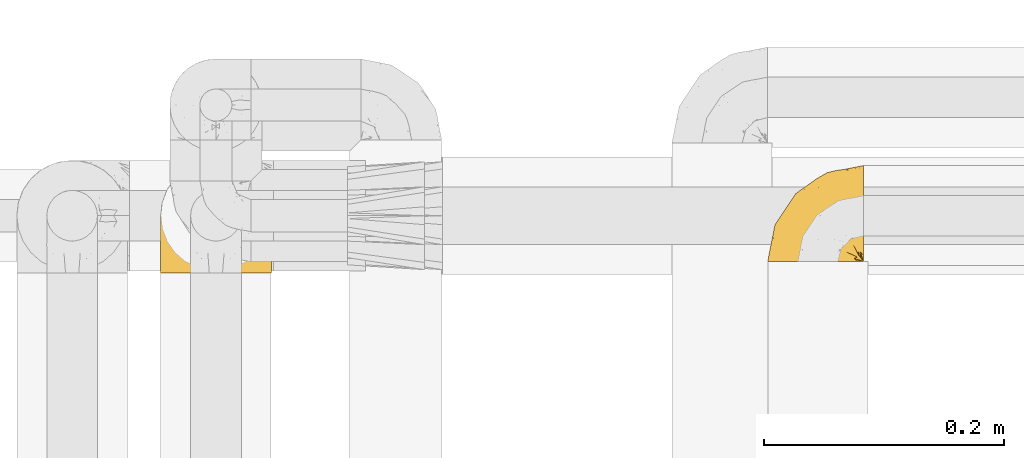
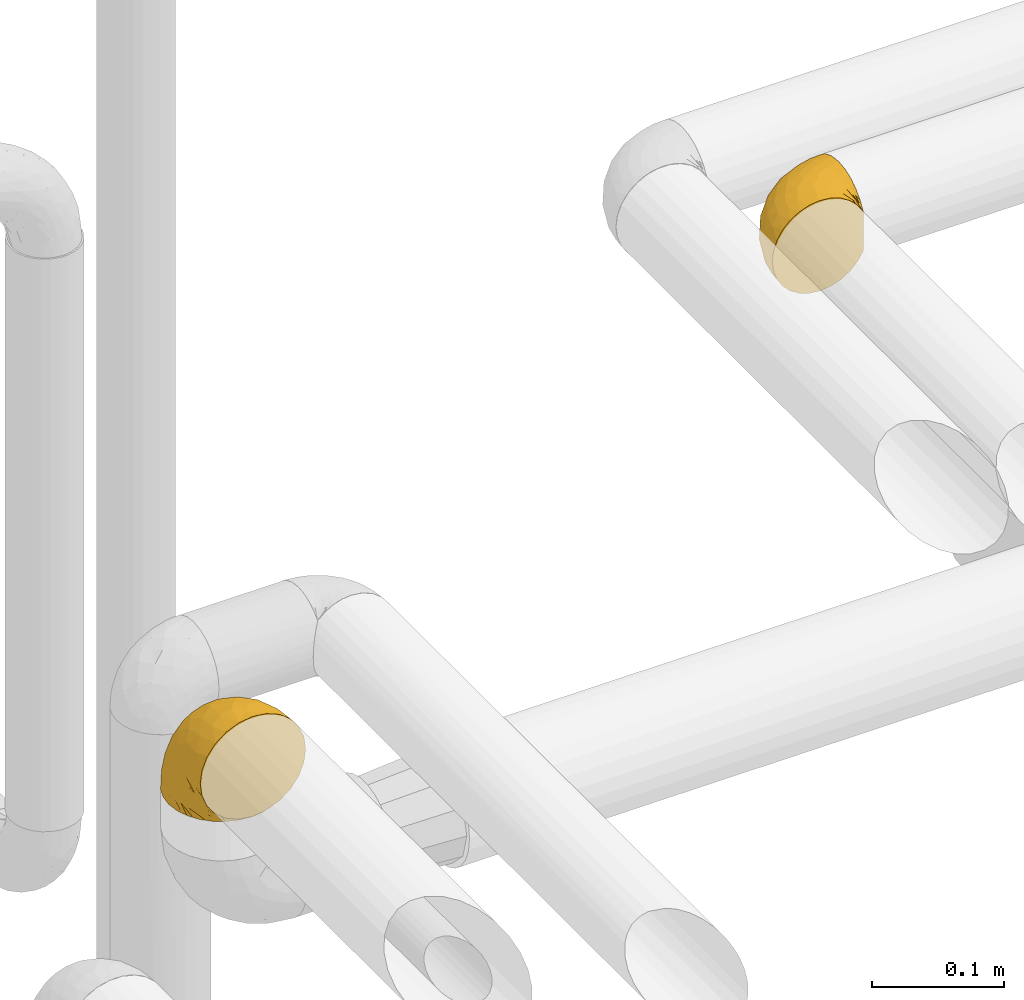
# One storey, part 429 of 827: 2 coverings.
"""IFC2X3 building model written with IfcOpenShell, lengths in millimetres."""

from ifc_helpers import new_model, entity, si_unit, converted_unit, derived_unit, direction, frame, origin, place, context, subcontext, project, spatial, faceted_brep, element, save


model = new_model("IFC2X3")

# Units and contexts
model_context = context("Model", 3, precision=0.01, world=origin(), true_north=direction((6.12303176911189e-17, 1.0)))
body_context = subcontext(model_context, "Body", "Model", "MODEL_VIEW")
ifc_project = project(units=[si_unit("LENGTHUNIT", "METRE", prefix="MILLI"), si_unit("AREAUNIT", "SQUARE_METRE"), si_unit("VOLUMEUNIT", "CUBIC_METRE"), converted_unit("PLANEANGLEUNIT", "DEGREE", entity("IfcRatioMeasure", 0.0174532925199433), si_unit("PLANEANGLEUNIT", "RADIAN"), dimensions=[0, 0, 0, 0, 0, 0, 0]), si_unit("MASSUNIT", "GRAM", prefix="KILO"), derived_unit("MASSDENSITYUNIT", [(si_unit("MASSUNIT", "GRAM", prefix="KILO"), 1), (si_unit("LENGTHUNIT", "METRE"), -3)]), derived_unit("MOMENTOFINERTIAUNIT", [(si_unit("LENGTHUNIT", "METRE"), 4)]), si_unit("TIMEUNIT", "SECOND"), si_unit("FREQUENCYUNIT", "HERTZ"), si_unit("THERMODYNAMICTEMPERATUREUNIT", "DEGREE_CELSIUS"), derived_unit("THERMALTRANSMITTANCEUNIT", [(si_unit("MASSUNIT", "GRAM", prefix="KILO"), 1), (si_unit("THERMODYNAMICTEMPERATUREUNIT", "KELVIN"), -1), (si_unit("TIMEUNIT", "SECOND"), -3)]), derived_unit("VOLUMETRICFLOWRATEUNIT", [(si_unit("LENGTHUNIT", "METRE"), 3), (si_unit("TIMEUNIT", "SECOND"), -1)]), derived_unit("MASSFLOWRATEUNIT", [(si_unit("MASSUNIT", "GRAM", prefix="KILO"), 1), (si_unit("TIMEUNIT", "SECOND"), -1)]), derived_unit("ROTATIONALFREQUENCYUNIT", [(si_unit("TIMEUNIT", "SECOND"), -1)]), si_unit("ELECTRICCURRENTUNIT", "AMPERE"), si_unit("ELECTRICVOLTAGEUNIT", "VOLT"), si_unit("POWERUNIT", "WATT"), si_unit("FORCEUNIT", "NEWTON", prefix="KILO"), si_unit("ILLUMINANCEUNIT", "LUX"), si_unit("LUMINOUSFLUXUNIT", "LUMEN"), si_unit("LUMINOUSINTENSITYUNIT", "CANDELA"), derived_unit("USERDEFINED", [(si_unit("MASSUNIT", "GRAM", prefix="KILO"), -1), (si_unit("LENGTHUNIT", "METRE"), -2), (si_unit("TIMEUNIT", "SECOND"), 3), (si_unit("LUMINOUSFLUXUNIT", "LUMEN"), 1)]), derived_unit("LINEARVELOCITYUNIT", [(si_unit("LENGTHUNIT", "METRE"), 1), (si_unit("TIMEUNIT", "SECOND"), -1)]), si_unit("PRESSUREUNIT", "PASCAL"), derived_unit("USERDEFINED", [(si_unit("LENGTHUNIT", "METRE"), -2), (si_unit("MASSUNIT", "GRAM", prefix="KILO"), 1), (si_unit("TIMEUNIT", "SECOND"), -2)]), derived_unit("LINEARFORCEUNIT", [(si_unit("MASSUNIT", "GRAM", prefix="KILO"), 1), (si_unit("LENGTHUNIT", "METRE"), 1), (si_unit("TIMEUNIT", "SECOND"), -2), (si_unit("LENGTHUNIT", "METRE"), -1)]), derived_unit("PLANARFORCEUNIT", [(si_unit("MASSUNIT", "GRAM", prefix="KILO"), 1), (si_unit("LENGTHUNIT", "METRE"), 1), (si_unit("TIMEUNIT", "SECOND"), -2), (si_unit("LENGTHUNIT", "METRE"), -2)])], contexts=[model_context])

# Site, building, storey
site_placement = place(None, origin())
site = spatial("IfcSite", under=ifc_project, at=site_placement, CompositionType="ELEMENT")
building_placement = place(site_placement, origin())
building = spatial("IfcBuilding", under=site, at=building_placement, CompositionType="ELEMENT")
storey_placement = place(building_placement, frame((0.0, 0.0, 28200.0)))
storey = spatial("IfcBuildingStorey", under=building, at=storey_placement, Name="08", CompositionType="ELEMENT", Elevation=28200.0)

# Coverings
covering_1_placement = place(storey_placement, frame((54648.74, 17460.4, 2956.55)))
element("IfcCovering", 1, at=covering_1_placement, inside=storey, Name=":ADSK_", ObjectType=":ADSK_", PredefinedType="INSULATION", context=body_context, shape_type="Brep", body=[
    faceted_brep([(25.28, 1.6, 81.15), (17.35, 1.6, 76.16), (10.72, 1.6, 69.53), (5.74, 1.6, 61.6), (2.64, 1.6, 52.75), (1.6, 1.6, 43.45), (2.65, 1.6, 34.13), (5.74, 1.6, 25.28), (10.73, 1.6, 17.35), (17.36, 1.6, 10.72), (25.29, 1.6, 5.74), (34.14, 1.6, 2.64), (43.45, 1.6, 1.6), (52.82, 1.6, 2.66), (61.71, 1.6, 5.79), (69.67, 1.6, 10.83), (76.31, 1.6, 17.53), (81.27, 1.6, 25.53), (81.27, 1.6, 26.45), (81.27, 1.6, 27.37), (81.27, 1.6, 28.17), (81.27, 1.6, 29.49), (81.27, 1.6, 30.81), (81.27, 1.6, 32.13), (81.27, 1.6, 33.45), (81.27, 1.6, 34.78), (81.27, 1.6, 36.1), (81.27, 1.6, 37.42), (81.27, 1.6, 38.74), (81.27, 1.6, 40.06), (81.27, 1.6, 41.38), (81.27, 1.6, 42.7), (81.27, 1.6, 44.02), (81.27, 1.6, 45.34), (81.27, 1.6, 46.66), (81.27, 1.6, 47.58), (81.27, 1.6, 48.5), (81.27, 1.6, 49.41), (81.27, 1.6, 50.33), (81.27, 1.6, 51.25), (81.27, 1.6, 52.17), (81.27, 1.6, 53.09), (81.27, 1.6, 54.01), (81.27, 1.6, 54.93), (81.27, 1.6, 55.85), (81.27, 1.6, 56.76), (81.27, 1.6, 57.68), (81.27, 1.6, 58.6), (81.27, 1.6, 59.52), (81.27, 1.6, 60.44), (81.27, 1.6, 61.36), (76.3, 1.6, 69.37), (69.66, 1.6, 76.07), (61.69, 1.6, 81.11), (52.8, 1.6, 84.24), (43.45, 1.6, 85.3), (34.13, 1.6, 84.24), (81.45, 6.74, 17.52), (81.45, 13.37, 10.83), (81.45, 21.34, 5.79), (81.45, 30.23, 2.66), (81.45, 39.6, 1.6), (81.45, 50.43, 3.02), (81.45, 60.52, 7.2), (81.45, 69.19, 13.85), (81.45, 75.84, 22.52), (81.45, 80.02, 32.61), (81.45, 81.45, 43.45), (81.45, 80.02, 54.28), (81.45, 75.84, 64.37), (81.45, 69.19, 73.04), (81.45, 60.52, 79.69), (81.45, 50.43, 83.87), (81.45, 39.6, 85.3), (81.45, 30.23, 84.23), (81.45, 21.34, 81.1), (81.45, 13.37, 76.06), (81.45, 6.74, 69.37), (81.45, 1.77, 61.36), (81.45, 1.77, 60.44), (81.45, 1.77, 59.12), (81.45, 1.77, 58.0), (81.45, 1.77, 56.88), (81.45, 1.77, 55.76), (81.45, 1.77, 54.64), (81.45, 1.77, 53.52), (81.45, 1.77, 52.4), (81.45, 1.77, 51.28), (81.45, 1.77, 50.16), (81.45, 1.77, 49.04), (81.45, 1.77, 47.92), (81.45, 1.77, 46.8), (81.45, 1.77, 45.68), (81.45, 1.77, 44.56), (81.45, 1.77, 43.45), (81.45, 1.77, 42.12), (81.45, 1.77, 40.8), (81.45, 1.77, 39.48), (81.45, 1.77, 38.16), (81.45, 1.77, 36.84), (81.45, 1.77, 35.52), (81.45, 1.77, 34.2), (81.45, 1.77, 32.88), (81.45, 1.77, 31.96), (81.45, 1.77, 31.05), (81.45, 1.77, 30.13), (81.45, 1.77, 29.21), (81.45, 1.77, 28.29), (81.45, 1.77, 27.37), (81.45, 1.77, 26.45), (81.45, 1.77, 25.53), (81.33, 1.73, 54.08), (81.32, 1.72, 55.16), (81.33, 1.73, 36.18), (81.32, 1.72, 35.13), (81.33, 1.73, 44.01), (81.32, 1.73, 45.08), (81.32, 1.72, 61.36), (81.32, 1.72, 59.98), (81.32, 1.72, 46.18), (81.32, 1.72, 26.74), (81.32, 1.72, 47.36), (81.32, 1.73, 29.67), (81.34, 1.74, 28.72), (81.32, 1.72, 39.77), (81.31, 1.71, 52.96), (81.33, 1.73, 51.84), (81.31, 1.71, 40.8), (81.32, 1.72, 41.87), (81.33, 1.73, 42.94), (81.32, 1.72, 27.77), (81.33, 1.73, 48.4), (81.32, 1.72, 37.21), (81.33, 1.73, 33.54), (81.32, 1.72, 32.49), (81.32, 1.72, 30.69), (81.32, 1.72, 50.69), (81.31, 1.71, 49.6), (81.32, 1.72, 56.32), (81.33, 1.73, 57.44), (81.31, 1.71, 58.88), (81.32, 1.72, 25.53), (81.3, 1.68, 61.36), (81.29, 1.64, 61.36), (81.29, 1.64, 25.53), (81.3, 1.68, 25.53), (81.4, 1.75, 61.36), (81.36, 1.74, 61.36), (81.36, 1.74, 25.53), (81.4, 1.75, 25.53), (81.3, 1.7, 31.59), (81.33, 1.73, 38.71), (74.06, 24.54, 3.97), (45.99, 11.1, 1.6), (58.35, 8.47, 3.97), (67.76, 9.11, 8.09), (66.18, 4.86, 8.09), (76.46, 5.0, 16.43), (77.33, 6.81, 15.73), (71.95, 37.05, 1.6), (72.25, 9.03, 10.79), (78.91, 9.47, 13.99), (76.42, 16.39, 8.08), (73.52, 3.95, 14.0), (76.9, 9.9, 12.83), (65.25, 22.7, 3.18), (62.45, 34.5, 1.6), (74.31, 37.68, 1.6), (59.38, 15.82, 3.28), (48.54, 20.6, 1.6), (67.72, 14.37, 6.28), (55.49, 27.55, 1.6), (79.73, 5.2, 19.06), (73.23, 14.88, 8.08), (45.36, 8.73, 1.6), (15.81, 44.27, 32.11), (6.4, 20.94, 29.62), (7.67, 32.15, 43.45), (68.46, 46.13, 2.45), (59.33, 42.67, 2.5), (48.7, 55.18, 9.73), (53.94, 67.27, 17.97), (65.02, 62.91, 10.24), (60.77, 51.5, 4.78), (72.07, 54.79, 4.78), (26.25, 25.78, 8.01), (22.29, 13.05, 8.01), (16.0, 18.46, 13.85), (46.93, 32.4, 2.42), (14.19, 31.07, 21.17), (58.46, 77.32, 35.73), (61.51, 75.62, 27.43), (4.64, 16.9, 43.45), (68.93, 71.69, 17.97), (29.62, 61.4, 35.71), (24.85, 54.47, 29.47), (38.55, 27.66, 3.41), (31.27, 14.53, 3.94), (9.35, 15.56, 21.17), (37.15, 42.26, 7.92), (47.07, 41.51, 4.25), (26.49, 36.93, 11.75), (23.01, 42.72, 18.31), (19.4, 44.68, 24.94), (48.06, 71.2, 28.78), (42.46, 70.48, 35.82), (50.89, 75.37, 43.45), (35.78, 63.65, 28.38), (24.98, 58.06, 43.45), (16.33, 45.11, 43.45), (66.14, 78.4, 43.45), (30.96, 54.95, 21.21), (41.83, 59.31, 16.48), (33.28, 49.01, 13.85), (37.94, 66.71, 43.45), (67.39, 53.75, 82.11), (58.47, 77.27, 51.41), (32.5, 61.6, 57.45), (15.79, 44.24, 54.78), (15.99, 18.46, 73.03), (9.34, 15.55, 65.7), (56.91, 60.14, 76.65), (63.5, 70.5, 68.92), (44.08, 63.0, 68.01), (26.24, 25.78, 78.88), (22.27, 13.05, 78.88), (31.26, 14.53, 82.94), (23.95, 48.5, 64.44), (63.79, 44.23, 84.49), (62.45, 34.5, 85.3), (71.95, 37.05, 85.3), (45.36, 8.73, 85.3), (67.83, 77.68, 57.84), (70.28, 64.08, 76.65), (42.11, 70.25, 51.19), (6.39, 20.93, 57.26), (43.54, 49.9, 78.14), (58.03, 49.6, 82.35), (14.18, 31.06, 65.7), (56.34, 39.62, 84.61), (48.09, 34.42, 84.36), (48.54, 20.6, 85.3), (55.49, 27.55, 85.3), (21.78, 33.36, 73.03), (38.54, 27.68, 83.48), (45.99, 11.1, 85.3), (72.79, 46.67, 84.54), (33.26, 49.0, 73.03), (35.53, 38.94, 79.54), (53.66, 73.05, 59.46), (43.03, 56.63, 73.5), (49.68, 43.85, 82.57), (74.06, 24.54, 82.92), (59.37, 15.82, 83.62), (58.34, 8.47, 82.92), (67.75, 9.12, 78.81), (78.91, 9.47, 72.9), (76.9, 9.91, 74.06), (78.08, 16.85, 78.81), (73.23, 14.88, 78.81), (79.73, 5.2, 67.83), (77.34, 6.81, 71.15), (73.51, 3.96, 72.91), (76.45, 5.0, 70.47), (66.41, 5.86, 78.81), (67.7, 14.38, 80.62), (72.24, 9.04, 76.11), (65.25, 22.7, 83.71)], [[[0, 1, 2, 3, 4, 5, 6, 7, 8, 9, 10, 11, 12, 13, 14, 15, 16, 17, 18, 19, 20, 21, 22, 23, 24, 25, 26, 27, 28, 29, 30, 31, 32, 33, 34, 35, 36, 37, 38, 39, 40, 41, 42, 43, 44, 45, 46, 47, 48, 49, 50, 51, 52, 53, 54, 55, 56]], [[57, 58, 59, 60, 61, 62, 63, 64, 65, 66, 67, 68, 69, 70, 71, 72, 73, 74, 75, 76, 77, 78, 79, 80, 81, 82, 83, 84, 85, 86, 87, 88, 89, 90, 91, 92, 93, 94, 95, 96, 97, 98, 99, 100, 101, 102, 103, 104, 105, 106, 107, 108, 109, 110]], [[111, 84, 112]], [[113, 26, 114]], [[114, 101, 100]], [[115, 93, 116]], [[79, 117, 118]], [[33, 116, 119]], [[117, 49, 118]], [[19, 18, 120]], [[119, 121, 34]], [[122, 21, 123]], [[97, 96, 124]], [[86, 125, 126]], [[116, 92, 119]], [[127, 96, 128]], [[32, 129, 115]], [[19, 120, 130]], [[121, 90, 131]], [[94, 115, 129]], [[115, 116, 32]], [[118, 49, 48]], [[113, 99, 132]], [[133, 114, 25]], [[24, 134, 133]], [[135, 22, 122]], [[136, 137, 88]], [[84, 83, 112]], [[138, 82, 139]], [[130, 20, 19]], [[118, 48, 140]], [[81, 140, 139]], [[123, 21, 20]], [[141, 120, 18]], [[139, 82, 81]], [[130, 107, 123]], [[49, 117, 142, 143, 50]], [[18, 17, 144, 145, 141]], [[79, 78, 146, 147, 117]], [[109, 141, 148, 149, 110]], [[102, 133, 134]], [[105, 135, 122]], [[118, 80, 79]], [[80, 118, 140]], [[120, 109, 108]], [[47, 46, 140, 48]], [[81, 80, 140]], [[44, 112, 138]], [[93, 115, 94]], [[46, 139, 140]], [[46, 45, 139]], [[139, 45, 138]], [[138, 112, 83]], [[85, 84, 111]], [[112, 43, 111]], [[83, 82, 138]], [[106, 122, 123]], [[105, 122, 106]], [[21, 122, 22]], [[124, 29, 28]], [[33, 32, 116]], [[128, 129, 31]], [[32, 31, 129]], [[34, 33, 119]], [[116, 93, 92]], [[129, 95, 94]], [[95, 129, 128]], [[41, 40, 125, 42]], [[119, 91, 121]], [[36, 35, 131, 37]], [[137, 131, 89]], [[121, 131, 35]], [[90, 121, 91]], [[119, 92, 91]], [[136, 126, 39]], [[125, 86, 85]], [[42, 125, 111]], [[85, 111, 125]], [[150, 23, 22]], [[130, 108, 107]], [[130, 123, 20]], [[107, 106, 123]], [[137, 37, 131]], [[136, 38, 137]], [[89, 88, 137]], [[131, 90, 89]], [[124, 151, 97]], [[40, 39, 126]], [[87, 126, 136]], [[86, 126, 87]], [[136, 88, 87]], [[40, 126, 125]], [[39, 38, 136]], [[95, 128, 96]], [[30, 128, 31]], [[29, 124, 127]], [[127, 128, 30]], [[151, 124, 28]], [[127, 30, 29]], [[127, 124, 96]], [[151, 98, 97]], [[45, 44, 138]], [[26, 113, 132]], [[113, 100, 99]], [[132, 151, 27]], [[27, 26, 132]], [[26, 25, 114]], [[100, 113, 114]], [[101, 133, 102]], [[133, 101, 114]], [[28, 27, 151]], [[132, 99, 98]], [[23, 134, 24]], [[25, 24, 133]], [[134, 23, 150]], [[135, 104, 150]], [[150, 104, 103]], [[103, 102, 134]], [[130, 120, 108]], [[109, 120, 141]], [[42, 111, 43]], [[112, 44, 43]], [[104, 135, 105]], [[134, 150, 103]], [[135, 150, 22]], [[35, 34, 121]], [[137, 38, 37]], [[98, 151, 132]], [[59, 152, 60]], [[13, 153, 154]], [[155, 156, 154]], [[157, 158, 141]], [[159, 60, 152]], [[160, 157, 155]], [[161, 162, 58]], [[58, 162, 59]], [[144, 16, 163]], [[58, 57, 161]], [[162, 161, 164]], [[157, 163, 155]], [[163, 16, 15]], [[57, 149, 161]], [[152, 165, 166]], [[157, 144, 163]], [[60, 159, 167, 61]], [[156, 14, 154]], [[163, 156, 155]], [[155, 154, 168]], [[168, 154, 169]], [[155, 170, 160]], [[57, 110, 149]], [[144, 17, 16]], [[156, 15, 14]], [[171, 165, 168]], [[158, 164, 172]], [[14, 13, 154]], [[157, 141, 145, 144]], [[173, 164, 158]], [[173, 160, 170]], [[171, 166, 165]], [[168, 165, 170]], [[168, 169, 171]], [[152, 173, 165]], [[170, 155, 168]], [[165, 173, 170]], [[160, 173, 158]], [[172, 149, 148]], [[148, 141, 158]], [[158, 157, 160]], [[152, 166, 159]], [[173, 152, 162]], [[59, 162, 152]], [[13, 12, 174, 153]], [[153, 169, 154]], [[15, 156, 163]], [[162, 164, 173]], [[172, 164, 161]], [[149, 172, 161]], [[158, 172, 148]], [[175, 176, 177]], [[178, 166, 179]], [[180, 181, 182]], [[183, 184, 178]], [[185, 186, 187]], [[171, 188, 179]], [[174, 12, 11]], [[189, 176, 175]], [[190, 66, 191]], [[176, 6, 192]], [[193, 65, 64]], [[63, 184, 182]], [[63, 182, 64]], [[65, 193, 191]], [[184, 63, 62]], [[175, 194, 195]], [[196, 169, 197]], [[174, 11, 197]], [[8, 7, 198]], [[187, 9, 8]], [[197, 169, 153, 174]], [[197, 11, 10]], [[186, 197, 10]], [[199, 180, 200]], [[197, 185, 196]], [[201, 189, 202]], [[201, 187, 189]], [[195, 203, 175]], [[191, 204, 190]], [[176, 7, 6]], [[177, 176, 192]], [[189, 198, 176]], [[65, 191, 66]], [[198, 187, 8]], [[205, 206, 190]], [[9, 186, 10]], [[181, 207, 204]], [[208, 175, 177, 209]], [[66, 190, 210]], [[211, 212, 213]], [[190, 204, 205]], [[180, 182, 183]], [[193, 182, 181]], [[62, 61, 167]], [[196, 185, 199]], [[196, 200, 188]], [[6, 5, 192]], [[176, 198, 7]], [[187, 198, 189]], [[187, 186, 9]], [[197, 186, 185]], [[200, 180, 183]], [[180, 213, 212]], [[179, 183, 178]], [[185, 201, 199]], [[210, 190, 206]], [[210, 67, 66]], [[205, 204, 207]], [[194, 205, 207]], [[194, 214, 205]], [[195, 194, 207]], [[208, 194, 175]], [[207, 211, 195]], [[202, 203, 211]], [[212, 207, 181]], [[202, 211, 213]], [[201, 202, 213]], [[189, 175, 203]], [[199, 201, 213]], [[187, 201, 185]], [[180, 199, 213]], [[196, 199, 200]], [[211, 203, 195]], [[189, 203, 202]], [[207, 212, 211]], [[180, 212, 181]], [[214, 194, 208]], [[214, 206, 205]], [[196, 188, 169]], [[181, 204, 191]], [[182, 193, 64]], [[191, 193, 181]], [[178, 62, 167]], [[182, 184, 183]], [[62, 178, 184]], [[178, 167, 159, 166]], [[171, 179, 166]], [[200, 183, 179]], [[179, 188, 200]], [[169, 188, 171]], [[71, 215, 72]], [[206, 216, 210]], [[217, 208, 218]], [[216, 68, 210]], [[219, 220, 2]], [[221, 222, 223]], [[224, 225, 226]], [[227, 223, 217]], [[228, 229, 230]], [[56, 231, 226]], [[232, 222, 69]], [[56, 55, 231]], [[70, 233, 71]], [[71, 233, 215]], [[0, 56, 226]], [[208, 217, 234]], [[218, 177, 235]], [[221, 236, 237]], [[238, 220, 219]], [[1, 219, 2]], [[68, 216, 232]], [[235, 3, 220]], [[235, 192, 4]], [[1, 0, 225]], [[228, 239, 229]], [[240, 241, 242]], [[243, 238, 219]], [[224, 226, 244]], [[226, 241, 244]], [[3, 235, 4]], [[69, 222, 70]], [[225, 219, 1]], [[218, 235, 238]], [[243, 219, 224]], [[218, 227, 217]], [[3, 2, 220]], [[218, 208, 209, 177]], [[226, 231, 245, 241]], [[215, 228, 246]], [[247, 248, 236]], [[248, 224, 244]], [[223, 222, 249]], [[233, 222, 221]], [[242, 239, 240]], [[248, 247, 243]], [[217, 223, 249]], [[250, 247, 236]], [[216, 234, 249]], [[218, 238, 227]], [[192, 235, 177]], [[192, 5, 4]], [[72, 246, 73]], [[235, 220, 238]], [[226, 225, 0]], [[219, 225, 224]], [[240, 248, 244]], [[239, 242, 229]], [[236, 248, 251]], [[68, 67, 210]], [[234, 216, 206]], [[216, 249, 232]], [[234, 206, 214, 208]], [[249, 234, 217]], [[222, 232, 249]], [[69, 68, 232]], [[246, 228, 230]], [[237, 228, 215]], [[243, 227, 238]], [[223, 227, 247]], [[73, 246, 230]], [[215, 246, 72]], [[248, 243, 224]], [[227, 243, 247]], [[237, 236, 251]], [[250, 221, 223]], [[222, 233, 70]], [[215, 233, 221]], [[221, 237, 215]], [[239, 237, 251]], [[237, 239, 228]], [[239, 251, 240]], [[248, 240, 251]], [[241, 240, 244]], [[221, 250, 236]], [[223, 247, 250]], [[74, 230, 252]], [[253, 254, 255]], [[146, 77, 256]], [[257, 258, 259]], [[260, 256, 257]], [[260, 261, 147]], [[75, 74, 252]], [[51, 143, 262]], [[263, 143, 142, 117]], [[256, 77, 76]], [[252, 258, 75]], [[253, 241, 254]], [[254, 245, 54]], [[258, 256, 76]], [[53, 52, 264]], [[255, 265, 253]], [[254, 264, 255]], [[255, 264, 262]], [[75, 258, 76]], [[265, 255, 266]], [[255, 262, 263]], [[51, 50, 143]], [[54, 245, 231, 55]], [[51, 262, 52]], [[253, 267, 242]], [[254, 54, 53]], [[266, 259, 265]], [[146, 78, 77]], [[263, 117, 261]], [[146, 256, 260]], [[257, 259, 261]], [[267, 253, 265]], [[229, 267, 252]], [[242, 267, 229]], [[242, 241, 253]], [[252, 267, 259]], [[255, 263, 266]], [[259, 267, 265]], [[261, 117, 147]], [[263, 261, 266]], [[259, 266, 261]], [[230, 74, 73]], [[230, 229, 252]], [[259, 258, 252]], [[254, 241, 245]], [[53, 264, 254]], [[52, 262, 264]], [[143, 263, 262]], [[258, 257, 256]], [[261, 260, 257]], [[146, 260, 147]]]),
])
covering_2_placement = place(storey_placement, frame((54141.99, 17450.4, 2650.4)))
element("IfcCovering", 2, at=covering_2_placement, inside=storey, Name=":ADSK_", ObjectType=":ADSK_", PredefinedType="INSULATION", context=body_context, shape_type="Brep", body=[
    faceted_brep([(11.68, 78.41, 1.6), (19.0, 85.72, 1.6), (27.76, 91.22, 1.6), (37.52, 94.64, 1.6), (47.8, 95.8, 1.6), (58.08, 94.64, 1.6), (67.85, 91.22, 1.6), (76.61, 85.71, 1.6), (83.92, 78.39, 1.6), (89.42, 69.63, 1.6), (92.84, 59.87, 1.6), (94.0, 49.6, 1.6), (93.53, 45.45, 1.6), (93.18, 42.38, 1.6), (92.84, 39.31, 1.6), (91.13, 34.43, 1.6), (89.42, 29.54, 1.6), (86.66, 25.16, 1.6), (83.91, 20.78, 1.6), (80.25, 17.13, 1.6), (76.59, 13.47, 1.6), (67.83, 7.97, 1.6), (62.95, 6.26, 1.6), (58.07, 4.55, 1.6), (47.8, 3.4, 1.6), (37.51, 4.55, 1.6), (32.63, 6.26, 1.6), (27.74, 7.97, 1.6), (18.98, 13.48, 1.6), (15.33, 17.14, 1.6), (11.67, 20.8, 1.6), (8.92, 25.18, 1.6), (6.17, 29.56, 1.6), (4.46, 34.44, 1.6), (2.75, 39.32, 1.6), (2.41, 42.39, 1.6), (2.06, 45.45, 1.6), (1.6, 49.6, 1.6), (2.75, 59.88, 1.6), (6.17, 69.65, 1.6), (47.8, 1.6, 3.4), (59.75, 1.6, 4.97), (70.9, 1.6, 9.58), (75.68, 1.6, 13.26), (80.46, 1.6, 16.93), (84.13, 1.6, 21.71), (87.81, 1.6, 26.5), (90.11, 1.6, 32.07), (92.42, 1.6, 37.64), (92.9, 1.6, 41.25), (93.17, 1.6, 43.34), (93.45, 1.6, 45.42), (94.0, 1.6, 49.6), (92.42, 1.6, 61.55), (87.81, 1.6, 72.7), (80.46, 1.6, 82.26), (70.9, 1.6, 89.61), (59.75, 1.6, 94.22), (47.8, 1.6, 95.8), (35.84, 1.6, 94.22), (24.7, 1.6, 89.61), (15.13, 1.6, 82.26), (7.78, 1.6, 72.7), (3.17, 1.6, 61.55), (1.6, 1.6, 49.6), (2.14, 1.6, 45.42), (2.69, 1.6, 41.25), (3.17, 1.6, 37.64), (5.48, 1.6, 32.07), (7.78, 1.6, 26.5), (11.46, 1.6, 21.71), (15.13, 1.6, 16.93), (19.91, 1.6, 13.26), (24.7, 1.6, 9.58), (35.84, 1.6, 4.97), (23.61, 36.81, 81.55), (31.99, 23.28, 90.4), (35.87, 45.8, 83.0), (47.8, 30.7, 91.18), (40.43, 21.2, 93.13), (47.8, 12.96, 94.0), (31.83, 66.19, 66.19), (23.37, 54.51, 70.92), (21.41, 17.98, 85.95), (3.07, 36.69, 49.74), (1.6, 35.54, 35.54), (1.6, 31.64, 38.14), (1.6, 27.75, 40.74), (1.6, 23.86, 43.34), (1.6, 19.96, 45.94), (13.45, 22.8, 77.59), (15.25, 42.67, 71.17), (8.07, 33.21, 65.81), (16.0, 59.45, 59.03), (17.34, 71.5, 45.85), (10.58, 62.66, 45.79), (5.34, 54.5, 41.42), (2.39, 47.57, 34.51), (8.36, 48.81, 56.04), (10.04, 74.98, 15.15), (2.59, 18.7, 56.51), (6.28, 15.75, 68.39), (34.28, 91.17, 23.33), (38.73, 85.28, 42.86), (27.25, 82.58, 39.42), (29.88, 75.78, 53.58), (38.6, 74.98, 59.17), (23.44, 67.27, 59.06), (25.25, 87.38, 22.63), (17.23, 82.04, 20.55), (47.8, 94.0, 12.96), (47.8, 77.8, 56.96), (47.8, 67.38, 67.38), (2.53, 56.2, 18.72), (1.6, 48.85, 5.33), (1.6, 48.11, 9.07), (1.6, 47.57, 11.79), (1.6, 47.03, 14.51), (1.6, 46.48, 17.24), (1.6, 45.94, 19.96), (5.71, 65.78, 21.03), (1.6, 17.24, 46.48), (1.6, 14.51, 47.03), (1.6, 11.79, 47.57), (1.6, 9.07, 48.11), (1.6, 7.2, 48.48), (1.6, 5.33, 48.85), (47.8, 91.18, 30.7), (1.6, 43.34, 23.86), (1.6, 40.74, 27.75), (1.6, 38.14, 31.64), (11.89, 72.73, 31.26), (47.8, 56.96, 77.8), (39.69, 62.23, 72.75), (47.8, 84.49, 43.83), (47.8, 43.83, 84.49), (13.84, 12.05, 14.58), (9.16, 18.95, 16.17), (15.79, 13.02, 10.82), (25.75, 8.34, 4.64), (16.09, 14.63, 7.71), (7.51, 11.09, 25.13), (3.99, 13.66, 32.66), (2.66, 20.08, 34.94), (3.16, 9.61, 36.76), (2.35, 9.48, 40.48), (2.23, 16.1, 39.25), (38.35, 3.42, 3.69), (6.18, 26.63, 13.99), (2.7, 33.72, 21.85), (2.93, 34.77, 17.93), (16.01, 6.75, 15.11), (9.08, 13.31, 21.14), (9.3, 21.11, 12.7), (11.68, 19.94, 7.21), (4.65, 8.67, 32.27), (3.65, 26.11, 25.68), (3.61, 29.3, 22.18), (12.8, 6.32, 18.79), (2.43, 39.92, 10.12), (6.83, 27.05, 9.47), (21.65, 6.04, 10.45), (3.7, 34.4, 11.29), (47.8, 2.87, 2.87), (3.37, 20.92, 31.16), (7.03, 27.43, 6.31), (7.87, 7.54, 25.62), (7.26, 18.45, 21.18), (3.41, 23.88, 28.81), (23.81, 7.77, 7.45), (86.5, 13.3, 21.14), (88.08, 11.09, 25.13), (82.79, 6.33, 18.79), (94.0, 9.07, 48.11), (94.0, 5.33, 48.85), (94.0, 14.51, 47.03), (94.0, 11.79, 47.57), (57.24, 3.42, 3.69), (71.76, 7.76, 7.44), (94.0, 47.03, 14.51), (94.0, 47.57, 11.79), (94.0, 48.85, 5.33), (94.0, 48.11, 9.07), (79.49, 14.62, 7.71), (88.75, 27.03, 9.47), (92.93, 20.08, 34.94), (92.22, 20.92, 31.16), (94.0, 27.75, 40.74), (94.0, 31.64, 38.14), (92.43, 9.61, 36.76), (93.24, 9.48, 40.48), (69.82, 8.33, 4.63), (79.57, 6.74, 15.11), (81.74, 12.04, 14.58), (94.0, 23.86, 43.34), (94.0, 19.96, 45.94), (93.36, 16.1, 39.25), (83.9, 19.93, 7.21), (86.28, 21.1, 12.69), (93.16, 39.92, 10.14), (92.88, 33.68, 21.81), (91.98, 29.28, 22.19), (89.41, 26.62, 14.0), (91.93, 26.08, 25.69), (86.42, 18.93, 16.17), (88.82, 27.87, 6.66), (92.66, 34.75, 17.92), (73.93, 6.04, 10.45), (94.0, 38.14, 31.64), (79.5, 12.79, 10.64), (91.89, 34.41, 11.31), (94.0, 45.94, 19.96), (94.0, 43.34, 23.86), (94.0, 40.74, 27.75), (91.6, 13.66, 32.66), (94.0, 17.24, 46.48), (90.94, 8.67, 32.27), (94.0, 35.54, 35.54), (92.16, 23.83, 28.77), (88.32, 18.43, 21.17), (86.13, 6.03, 23.36), (94.0, 46.48, 17.24), (93.2, 34.52, 47.58), (55.16, 21.2, 93.13), (82.02, 23.82, 77.44), (84.29, 41.32, 66.78), (76.94, 47.62, 71.68), (68.33, 52.66, 74.96), (71.98, 36.81, 81.55), (92.52, 49.75, 36.7), (92.9, 19.07, 56.9), (59.72, 45.8, 83.0), (63.6, 23.28, 90.4), (88.89, 21.35, 67.83), (74.18, 17.98, 85.95), (68.35, 82.57, 39.41), (61.33, 91.17, 23.33), (56.86, 85.27, 42.87), (68.62, 73.89, 53.92), (63.76, 66.19, 66.19), (72.19, 62.43, 64.12), (88.69, 63.53, 33.13), (92.19, 58.45, 23.1), (89.75, 67.16, 16.98), (59.86, 76.72, 55.72), (55.9, 62.22, 72.75), (77.99, 81.54, 23.77), (85.21, 74.8, 18.41), (74.99, 75.83, 43.7), (90.23, 41.45, 54.53), (70.75, 88.2, 17.73), (81.72, 71.6, 38.98), (86.53, 56.23, 50.28), (79.6, 59.44, 59.02)], [[[0, 1, 2, 3, 4, 5, 6, 7, 8, 9, 10, 11, 12, 13, 14, 15, 16, 17, 18, 19, 20, 21, 22, 23, 24, 25, 26, 27, 28, 29, 30, 31, 32, 33, 34, 35, 36, 37, 38, 39]], [[40, 41, 42, 43, 44, 45, 46, 47, 48, 49, 50, 51, 52, 53, 54, 55, 56, 57, 58, 59, 60, 61, 62, 63, 64, 65, 66, 67, 68, 69, 70, 71, 72, 73, 74]], [[75, 76, 77]], [[78, 79, 80]], [[77, 81, 82]], [[76, 75, 83]], [[84, 85, 86, 87, 88, 89]], [[90, 91, 92]], [[76, 60, 59]], [[93, 94, 95]], [[90, 62, 61]], [[83, 61, 60]], [[96, 97, 84]], [[98, 93, 95]], [[0, 39, 99]], [[100, 84, 89]], [[62, 101, 63]], [[2, 102, 3]], [[92, 84, 100]], [[103, 102, 104]], [[103, 105, 106]], [[93, 107, 94]], [[1, 108, 2]], [[92, 101, 90]], [[108, 1, 109]], [[102, 110, 3]], [[93, 82, 107]], [[102, 108, 104]], [[111, 106, 112]], [[109, 0, 99]], [[113, 37, 114, 115, 116, 117, 118, 119]], [[120, 38, 113]], [[100, 89, 121, 122, 123, 124, 125, 126, 64]], [[127, 102, 103]], [[97, 119, 128, 129, 130, 85]], [[99, 120, 131]], [[132, 133, 77]], [[59, 80, 79]], [[1, 0, 109]], [[98, 84, 92]], [[94, 109, 131]], [[120, 39, 38]], [[93, 91, 82]], [[104, 94, 105]], [[97, 113, 119]], [[95, 120, 96]], [[83, 90, 61]], [[91, 93, 98]], [[64, 63, 100]], [[100, 63, 101]], [[77, 76, 79]], [[133, 106, 81]], [[84, 97, 85]], [[113, 96, 120]], [[113, 97, 96]], [[37, 113, 38]], [[110, 102, 127]], [[110, 4, 3]], [[103, 111, 134, 127]], [[90, 75, 91]], [[82, 81, 107]], [[91, 75, 82]], [[77, 82, 75]], [[76, 83, 60]], [[90, 83, 75]], [[105, 107, 81]], [[94, 131, 95]], [[105, 94, 107]], [[109, 94, 104]], [[120, 95, 131]], [[98, 95, 96]], [[84, 98, 96]], [[98, 92, 91]], [[106, 105, 81]], [[103, 104, 105]], [[112, 106, 133]], [[103, 106, 111]], [[112, 133, 132]], [[81, 77, 133]], [[77, 78, 135, 132]], [[120, 99, 39]], [[109, 99, 131]], [[59, 58, 80]], [[59, 79, 76]], [[90, 101, 62]], [[100, 101, 92]], [[2, 108, 102]], [[109, 104, 108]], [[78, 77, 79]], [[136, 137, 138]], [[27, 139, 140]], [[141, 142, 143]], [[144, 145, 121]], [[146, 89, 88]], [[147, 139, 25]], [[148, 149, 150]], [[136, 151, 152]], [[147, 40, 74]], [[24, 147, 25]], [[140, 153, 154]], [[33, 116, 34]], [[73, 72, 151]], [[114, 37, 36, 35, 34, 116, 115]], [[146, 155, 144]], [[156, 85, 130]], [[157, 149, 148]], [[151, 158, 152]], [[117, 33, 159]], [[29, 154, 160]], [[161, 74, 73]], [[162, 128, 119]], [[66, 65, 64, 126, 125, 124, 123, 122, 67]], [[163, 147, 24]], [[27, 140, 28]], [[149, 129, 150]], [[139, 27, 26, 25]], [[68, 144, 69]], [[129, 128, 150]], [[164, 87, 86]], [[130, 129, 149]], [[122, 145, 67]], [[154, 153, 148]], [[162, 119, 159]], [[165, 30, 160]], [[150, 160, 148]], [[128, 162, 150]], [[30, 165, 31]], [[145, 144, 68]], [[89, 146, 144]], [[87, 164, 143]], [[166, 155, 142]], [[88, 87, 143]], [[162, 160, 150]], [[160, 30, 29]], [[154, 29, 28]], [[140, 154, 28]], [[160, 154, 148]], [[140, 137, 153]], [[157, 148, 153]], [[156, 130, 157]], [[153, 137, 157]], [[157, 137, 156]], [[167, 137, 136]], [[168, 85, 156]], [[152, 168, 167]], [[167, 168, 156]], [[164, 152, 141]], [[71, 158, 72]], [[152, 167, 136]], [[88, 142, 146]], [[144, 155, 69]], [[146, 142, 155]], [[70, 166, 71]], [[142, 141, 166]], [[70, 69, 155]], [[141, 158, 71]], [[161, 73, 151]], [[138, 137, 140]], [[161, 136, 169]], [[136, 161, 151]], [[74, 161, 169]], [[152, 158, 141]], [[151, 72, 158]], [[168, 152, 164]], [[137, 167, 156]], [[164, 86, 168]], [[85, 168, 86]], [[116, 33, 117]], [[130, 149, 157]], [[67, 145, 68]], [[121, 89, 144]], [[145, 122, 121]], [[40, 147, 163]], [[169, 147, 74]], [[159, 33, 32]], [[162, 159, 32]], [[159, 119, 118, 117]], [[139, 147, 169]], [[139, 169, 138]], [[162, 32, 31]], [[141, 143, 164]], [[88, 143, 142]], [[71, 166, 141]], [[155, 166, 70]], [[139, 138, 140]], [[169, 136, 138]], [[160, 162, 165]], [[162, 31, 165]], [[170, 171, 172]], [[173, 174, 52, 51, 50, 49, 48, 175, 176]], [[177, 178, 41]], [[179, 15, 180]], [[12, 11, 181, 182, 180, 14, 13]], [[183, 21, 20]], [[19, 18, 184]], [[185, 186, 187]], [[186, 188, 187]], [[43, 172, 44]], [[189, 190, 47]], [[23, 22, 21, 191]], [[170, 192, 193]], [[40, 163, 177]], [[194, 195, 196]], [[24, 23, 177]], [[197, 198, 183]], [[199, 15, 179]], [[47, 46, 189]], [[200, 201, 202]], [[201, 203, 204]], [[205, 206, 184]], [[207, 41, 178]], [[16, 15, 199]], [[14, 180, 15]], [[202, 201, 198]], [[208, 201, 200]], [[163, 24, 177]], [[48, 47, 190]], [[196, 195, 189]], [[197, 184, 202]], [[204, 193, 209]], [[210, 211, 212]], [[206, 212, 213]], [[205, 17, 210]], [[184, 206, 202]], [[210, 212, 206]], [[185, 194, 214]], [[189, 215, 190]], [[216, 45, 214]], [[186, 171, 170]], [[189, 216, 196]], [[197, 20, 19]], [[194, 185, 187]], [[197, 183, 20]], [[184, 197, 19]], [[197, 202, 198]], [[206, 200, 202]], [[204, 183, 198]], [[201, 208, 203]], [[203, 208, 217]], [[204, 198, 201]], [[217, 188, 218]], [[193, 219, 170]], [[171, 186, 185]], [[170, 218, 186]], [[170, 219, 218]], [[42, 207, 192]], [[171, 220, 172]], [[216, 189, 46]], [[214, 194, 196]], [[44, 220, 45]], [[214, 196, 216]], [[216, 46, 45]], [[214, 45, 220]], [[192, 43, 42]], [[204, 203, 219]], [[207, 193, 192]], [[209, 193, 178]], [[41, 207, 42]], [[193, 207, 178]], [[43, 192, 172]], [[170, 172, 192]], [[204, 219, 193]], [[219, 203, 218]], [[217, 218, 203]], [[188, 186, 218]], [[206, 213, 200]], [[208, 200, 213]], [[199, 210, 16]], [[215, 189, 195]], [[215, 175, 190]], [[175, 48, 190]], [[199, 179, 221, 211]], [[210, 199, 211]], [[23, 191, 177]], [[40, 177, 41]], [[178, 177, 191]], [[21, 183, 191]], [[209, 191, 183]], [[205, 18, 17]], [[17, 16, 210]], [[171, 185, 214]], [[172, 220, 44]], [[214, 220, 171]], [[191, 209, 178]], [[204, 209, 183]], [[206, 205, 210]], [[18, 205, 184]], [[222, 195, 194, 187, 188, 217]], [[57, 223, 80]], [[224, 225, 226]], [[226, 227, 228]], [[229, 217, 208, 213, 212, 211]], [[230, 52, 174, 173, 176, 175, 215, 195]], [[231, 232, 228]], [[231, 78, 223]], [[223, 57, 232]], [[224, 233, 225]], [[233, 54, 53]], [[234, 232, 56]], [[56, 55, 234]], [[234, 224, 228]], [[235, 236, 237]], [[224, 55, 54]], [[238, 239, 240]], [[52, 230, 53]], [[241, 242, 243]], [[239, 244, 245]], [[11, 10, 242]], [[236, 6, 5]], [[7, 246, 8]], [[8, 247, 9]], [[238, 248, 235]], [[222, 229, 249]], [[242, 211, 221, 179, 180, 182, 181, 11]], [[233, 53, 230]], [[111, 112, 244]], [[250, 6, 236]], [[247, 251, 241]], [[6, 250, 7]], [[127, 236, 110]], [[249, 229, 252]], [[247, 8, 246]], [[235, 246, 250]], [[236, 5, 110]], [[235, 244, 238]], [[237, 236, 127]], [[243, 9, 247]], [[252, 229, 241]], [[56, 232, 57]], [[222, 230, 195]], [[225, 249, 252]], [[249, 233, 230]], [[54, 233, 224]], [[231, 228, 227]], [[245, 132, 231]], [[249, 225, 233]], [[226, 225, 253]], [[235, 250, 236]], [[246, 7, 250]], [[251, 247, 246]], [[243, 247, 241]], [[248, 246, 235]], [[252, 251, 253]], [[229, 222, 217]], [[230, 222, 249]], [[5, 4, 110]], [[237, 127, 134, 111]], [[238, 244, 239]], [[224, 234, 55]], [[232, 234, 228]], [[242, 241, 229]], [[10, 9, 243]], [[211, 242, 229]], [[10, 243, 242]], [[80, 223, 78]], [[80, 58, 57]], [[231, 223, 232]], [[227, 240, 239]], [[224, 226, 228]], [[240, 226, 253]], [[227, 239, 245]], [[226, 240, 227]], [[251, 248, 253]], [[240, 253, 248]], [[244, 235, 237]], [[237, 111, 244]], [[132, 245, 112]], [[112, 245, 244]], [[135, 78, 231, 132]], [[227, 245, 231]], [[248, 238, 240]], [[246, 248, 251]], [[251, 252, 241]], [[225, 252, 253]]]),
])

save(model, "model.ifc")
